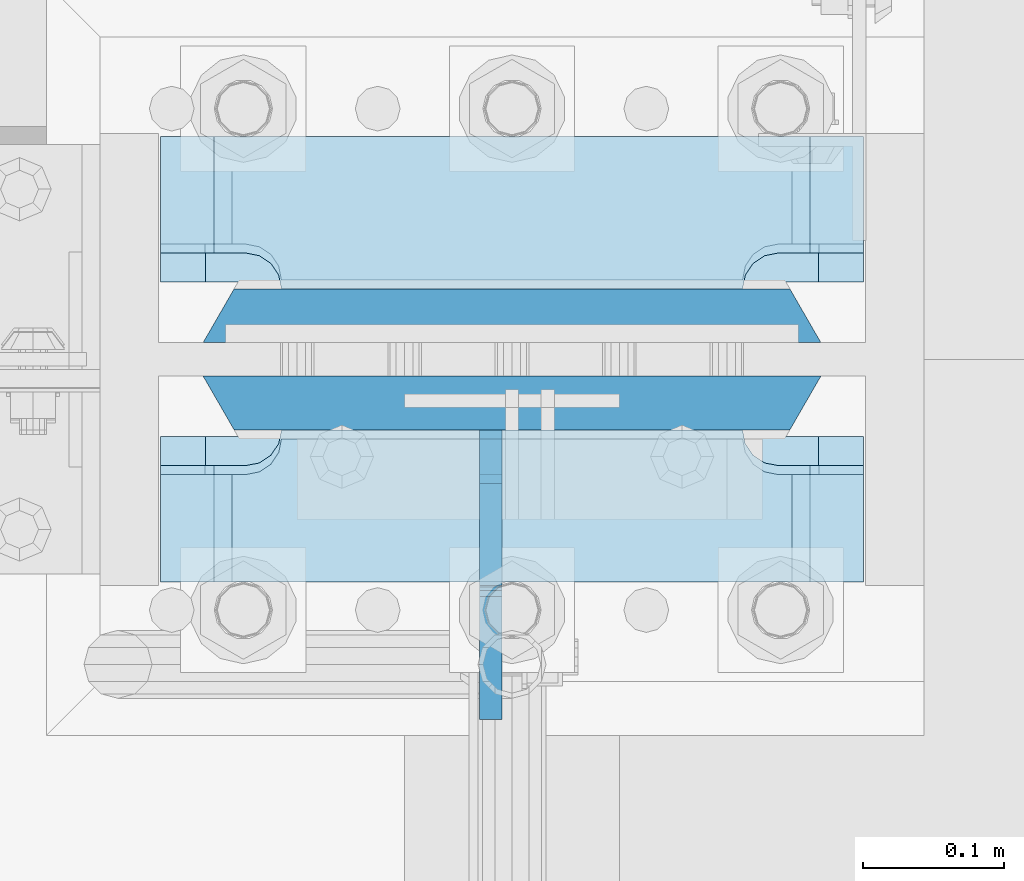
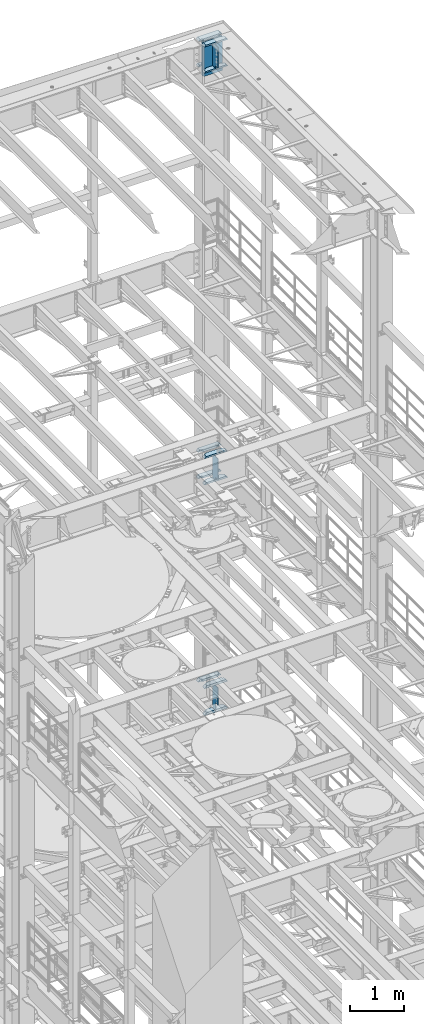
# One storey, part 1829 of 1876: 16 plates, 2 elements without a shape of their own.
"""IFC2X3 building model written with IfcOpenShell, lengths in millimetres."""

from ifc_helpers import new_model, si_unit, frame, origin_with_axes, place, context, subcontext, project, spatial, faceted_brep, material, type_object, element, aggregate, save


model = new_model("IFC2X3")

# Units and contexts
model_context = context("Model", 3, precision=1e-05, world=origin_with_axes())
body_context = subcontext(model_context, "Body", "Model", "MODEL_VIEW")
ifc_project = project(units=[si_unit("LENGTHUNIT", "METRE", prefix="MILLI"), si_unit("AREAUNIT", "SQUARE_METRE"), si_unit("VOLUMEUNIT", "CUBIC_METRE"), si_unit("MASSUNIT", "GRAM", prefix="KILO"), si_unit("TIMEUNIT", "SECOND"), si_unit("PLANEANGLEUNIT", "RADIAN"), si_unit("SOLIDANGLEUNIT", "STERADIAN"), si_unit("THERMODYNAMICTEMPERATUREUNIT", "DEGREE_CELSIUS"), si_unit("LUMINOUSINTENSITYUNIT", "LUMEN")], contexts=[model_context])

# Site, building, storey
site_placement = place(None, origin_with_axes())
site = spatial("IfcSite", under=ifc_project, at=site_placement, CompositionType="ELEMENT")
building_placement = place(site_placement, origin_with_axes())
building = spatial("IfcBuilding", under=site, at=building_placement, Name="Undefined", CompositionType="ELEMENT")
storey_placement = place(building_placement, origin_with_axes())
storey = spatial("IfcBuildingStorey", under=building, at=storey_placement, Name="Undefined", CompositionType="ELEMENT", Elevation=0.0)

# Assembly, plates
assembly_1_placement = place(storey_placement, origin_with_axes())
assembly_1 = element("IfcElementAssembly", 1, at=assembly_1_placement, inside=storey, Name="COLUMN", AssemblyPlace="NOTDEFINED", PredefinedType="RIGID_FRAME")
ifc_material_1 = material(Name="STEEL/A572-GR.50")
plate_type_1 = type_object("IfcPlateType", PredefinedType="NOTDEFINED")
plate_1_placement = place(assembly_1_placement, frame((7839.075, 13685.04375, 22523.45), z_axis=(-1.0, 0.0, 0.0), x_axis=(0.0, 0.0, -1.0)))
plate_1 = element("IfcPlate", 2, at=plate_1_placement, type_object=plate_type_1, material=ifc_material_1, Name="PLATE", context=body_context, shape_type="Brep", body=[
    faceted_brep([(0.0, 19.0500000000002, 416.152954742277), (0.0, -19.0500000000002, 438.149993896484), (742.950012207031, -19.0500000000002, 438.149993896484), (742.950012207031, 19.0500000000002, 416.152954742277), (742.950012207031, 19.0500000000002, 21.9970452577325), (0.0, 19.0500000000002, 21.9970452577367), (0.0, -19.0500000000002, 0.0), (742.950012207031, -19.0500000000002, 0.0)], [[[0, 1, 2, 3]], [[0, 3, 4, 5]], [[1, 0, 5, 6]], [[2, 1, 6, 7]], [[3, 2, 7, 4]], [[6, 5, 4, 7]]]),
])
plate_2_placement = place(assembly_1_placement, frame((7839.075, 13746.95625, 22523.45), z_axis=(-1.0, 0.0, 0.0), x_axis=(0.0, 0.0, -1.0)))
plate_2 = element("IfcPlate", 3, at=plate_2_placement, type_object=plate_type_1, material=ifc_material_1, Name="PLATE", context=body_context, shape_type="Brep", body=[
    faceted_brep([(0.0, -19.0500000000002, 416.152954749452), (742.950012207031, -19.0500000000002, 416.152954749372), (742.950012207031, 19.0500000000002, 438.149993896484), (0.0, 19.0500000000002, 438.149993896484), (742.950012207031, -19.0500000000002, 21.9970452506512), (742.950012207031, 19.0500000000002, 0.0), (-9.09494701772928e-13, 19.05, -1.81898940354586e-12), (0.0, -19.0500000000002, 21.9970452506512)], [[[0, 1, 2, 3]], [[2, 1, 4, 5]], [[3, 2, 5, 6]], [[0, 3, 6, 7]], [[1, 0, 7, 4]], [[6, 5, 4, 7]]]),
])

assembly_2_placement = place(storey_placement, origin_with_axes())
assembly_2 = element("IfcElementAssembly", 4, at=assembly_2_placement, inside=storey, Name="COLUMN", AssemblyPlace="NOTDEFINED", PredefinedType="RIGID_FRAME")
ifc_material_2 = material(Name="STEEL/A572-50")
plate_type_2 = type_object("IfcPlateType", PredefinedType="NOTDEFINED")
plate_3_placement = place(assembly_2_placement, frame((7370.7625, 13558.04375, 7524.75002441406), z_axis=(1.0, 0.0, 0.0), x_axis=(0.0, 1.0, 0.0)))
plate_3 = element("IfcPlate", 5, at=plate_3_placement, type_object=plate_type_2, material=ifc_material_2, Name="PLATE", context=body_context, shape_type="Brep", body=[
    faceted_brep([(76.1999988555908, -25.3999999999996, 498.475006103516), (76.1999988555908, 25.3999999999996, 447.975004579812), (0.0, 25.3999999999996, 447.975004579812), (0.0, -25.3999999999996, 498.475006103516), (76.1999988555908, 25.3999999999996, 50.5000015237032), (76.1999988555908, -25.3999999999996, 0.0), (0.0, -25.3999996185375, 0.0), (0.0, 25.3999999999996, 50.5000015237032), (76.1999988555908, 25.3999999999996, 60.3249988555908), (76.1999988555908, -25.3999999999996, 60.3249988555908), (78.1334587007668, -25.3999999999996, 70.045157891682), (78.1334587007668, 25.3999999999996, 70.045157891682), (83.6394865017228, -25.3999999999996, 78.2855108279893), (83.6394865017228, 25.3999999999996, 78.2855108279893), (91.8798394380301, -25.3999999999996, 83.7915386289454), (91.8798394380301, 25.3999999999996, 83.7915386289454), (101.599998474121, -25.3999999999996, 85.7249984741211), (101.599998474121, 25.3999999999996, 85.7249984741211), (101.599998474121, -25.3999999999996, 412.750007629395), (101.599998474121, 25.3999999999996, 412.750007629395), (91.8798394380301, -25.3999999999996, 414.68346747457), (91.8798394380301, 25.3999999999996, 414.68346747457), (83.6394865017219, -25.3999999999996, 420.189495275526), (83.6394865017219, 25.3999999999996, 420.189495275526), (78.1334587007659, -25.3999999999996, 428.429848211834), (78.1334587007659, 25.3999999999996, 428.429848211834), (76.1999988555908, -25.3999999999996, 438.150007247925), (76.1999988555908, 25.3999999999996, 438.150007247925)], [[[0, 1, 2, 3]], [[4, 5, 6, 7]], [[8, 9, 5, 4]], [[10, 9, 8, 11]], [[12, 10, 11, 13]], [[14, 12, 13, 15]], [[16, 14, 15, 17]], [[18, 16, 17, 19]], [[20, 18, 19, 21]], [[22, 20, 21, 23]], [[24, 22, 23, 25]], [[26, 24, 25, 27]], [[6, 5, 9, 10, 12, 14, 16, 18, 20, 22, 24, 26, 0, 3]], [[7, 6, 3, 2]], [[27, 25, 23, 21, 19, 17, 15, 13, 11, 8, 4, 7, 2, 1]], [[26, 27, 1, 0]]]),
])
plate_4_placement = place(assembly_2_placement, frame((7370.7625, 13772.35625, 8128.0), z_axis=(1.0, 0.0, 0.0), x_axis=(0.0, 1.0, 0.0)))
plate_4 = element("IfcPlate", 6, at=plate_4_placement, type_object=plate_type_2, material=ifc_material_2, Name="PLATE", context=body_context, shape_type="Brep", body=[
    faceted_brep([(101.599998474121, -25.3999999999996, 498.475006103516), (101.599998474121, 25.3999999999996, 447.975004579813), (25.3999996185303, 25.3999999999996, 447.975004579813), (25.3999996185303, -25.3999999999996, 498.475006103516), (23.4665397733534, -25.3999999999996, 428.429848211837), (25.3999996185303, -25.3999999999996, 438.150007247925), (25.3999996185303, 25.3999999999996, 438.150007247925), (23.4665397733534, 25.3999999999996, 428.429848211837), (17.9605119723965, -25.3999999999996, 420.189495275529), (17.9605119723965, 25.3999999999996, 420.189495275529), (9.72015903608917, -25.3999999999996, 414.683467474573), (9.72015903608917, 25.3999999999996, 414.683467474573), (0.0, -25.3999999999996, 412.750007629395), (0.0, 25.3999999999996, 412.750007629395), (0.0, -25.3999999999996, 85.7249984741211), (0.0, 25.3999999999996, 85.7249984741211), (9.72015903609099, -25.3999999999996, 83.7915386289451), (9.72015903609099, 25.3999999999996, 83.7915386289451), (17.9605119723983, -25.3999999999996, 78.2855108279891), (17.9605119723983, 25.3999999999996, 78.2855108279891), (23.4665397733552, -25.3999999999996, 70.0451578916818), (23.4665397733552, 25.3999999999996, 70.0451578916818), (25.3999996185303, -25.3999999999996, 60.3249988555908), (25.3999996185303, 25.3999999999996, 60.3249988555908), (25.3999996185303, 25.3999999999996, 50.5000015237028), (25.3999996185303, -25.3999999999996, 0.0), (101.599998474121, 25.3999999999996, 50.5000015237028), (101.599998474121, -25.3999999999996, 0.0)], [[[0, 1, 2, 3]], [[4, 5, 6, 7]], [[8, 4, 7, 9]], [[10, 8, 9, 11]], [[12, 10, 11, 13]], [[14, 12, 13, 15]], [[16, 14, 15, 17]], [[18, 16, 17, 19]], [[20, 18, 19, 21]], [[22, 20, 21, 23]], [[22, 23, 24, 25]], [[26, 27, 25, 24]], [[5, 4, 8, 10, 12, 14, 16, 18, 20, 22, 25, 27, 0, 3]], [[6, 5, 3, 2]], [[26, 24, 23, 21, 19, 17, 15, 13, 11, 9, 7, 6, 2, 1]], [[27, 26, 1, 0]]]),
])
plate_5_placement = place(assembly_2_placement, frame((7370.7625, 13558.04375, 8128.0), z_axis=(1.0, 0.0, 0.0), x_axis=(0.0, 1.0, 0.0)))
plate_5 = element("IfcPlate", 7, at=plate_5_placement, type_object=plate_type_2, material=ifc_material_2, Name="PLATE", context=body_context, shape_type="Brep", body=[
    faceted_brep([(76.1999988555908, -25.3999999999996, 498.475006103516), (76.1999988555908, 25.3999999999996, 447.975004579812), (0.0, 25.3999999999996, 447.975004579812), (0.0, -25.3999999999996, 498.475006103516), (76.1999988555908, 25.3999999999996, 50.5000015237032), (76.1999988555908, -25.3999999999996, 0.0), (0.0, -25.3999996185375, 0.0), (0.0, 25.3999999999996, 50.5000015237032), (76.1999988555908, 25.3999999999996, 60.3249988555908), (76.1999988555908, -25.3999999999996, 60.3249988555908), (78.1334587007668, -25.3999999999996, 70.045157891682), (78.1334587007668, 25.3999999999996, 70.045157891682), (83.6394865017228, -25.3999999999996, 78.2855108279893), (83.6394865017228, 25.3999999999996, 78.2855108279893), (91.8798394380301, -25.3999999999996, 83.7915386289454), (91.8798394380301, 25.3999999999996, 83.7915386289454), (101.599998474121, -25.3999999999996, 85.7249984741211), (101.599998474121, 25.3999999999996, 85.7249984741211), (101.599998474121, -25.3999999999996, 412.750007629395), (101.599998474121, 25.3999999999996, 412.750007629395), (91.8798394380301, -25.3999999999996, 414.68346747457), (91.8798394380301, 25.3999999999996, 414.68346747457), (83.6394865017219, -25.3999999999996, 420.189495275526), (83.6394865017219, 25.3999999999996, 420.189495275526), (78.1334587007659, -25.3999999999996, 428.429848211834), (78.1334587007659, 25.3999999999996, 428.429848211834), (76.1999988555908, -25.3999999999996, 438.150007247925), (76.1999988555908, 25.3999999999996, 438.150007247925)], [[[0, 1, 2, 3]], [[4, 5, 6, 7]], [[8, 9, 5, 4]], [[10, 9, 8, 11]], [[12, 10, 11, 13]], [[14, 12, 13, 15]], [[16, 14, 15, 17]], [[18, 16, 17, 19]], [[20, 18, 19, 21]], [[22, 20, 21, 23]], [[24, 22, 23, 25]], [[26, 24, 25, 27]], [[6, 5, 9, 10, 12, 14, 16, 18, 20, 22, 24, 26, 0, 3]], [[7, 6, 3, 2]], [[27, 25, 23, 21, 19, 17, 15, 13, 11, 8, 4, 7, 2, 1]], [[26, 27, 1, 0]]]),
])

# Plate
plate_type_3 = type_object("IfcPlateType", PredefinedType="NOTDEFINED")
plate_6_placement = place(assembly_1_placement, frame((7370.7625, 13766.00625, 21948.775012207), z_axis=(1.0, 0.0, 0.0), x_axis=(0.0, 1.0, 0.0)))
plate_6 = element("IfcPlate", 8, at=plate_6_placement, type_object=plate_type_3, material=ifc_material_2, Name="PLATE", context=body_context, shape_type="Brep", body=[
    faceted_brep([(107.949996948242, -15.875, 498.475006103516), (107.949996948242, 15.875, 467.025007631571), (25.3999996185303, 15.875, 467.025007631571), (25.3999996185303, -15.875, 498.475006103516), (23.4665397733534, -15.875, 428.429848211837), (25.3999996185303, -15.875, 438.150007247925), (25.3999996185303, 15.875, 438.150007247925), (23.4665397733534, 15.875, 428.429848211837), (17.9605119723965, -15.875, 420.189495275529), (17.9605119723965, 15.875, 420.189495275529), (9.72015903608917, -15.875, 414.683467474573), (9.72015903608917, 15.875, 414.683467474573), (0.0, -15.875, 412.750007629395), (0.0, 15.875, 412.750007629395), (0.0, -15.875, 85.7249984741211), (0.0, 15.875, 85.7249984741211), (9.72015903609099, -15.875, 83.7915386289454), (9.72015903609099, 15.875, 83.7915386289454), (17.9605119723983, -15.875, 78.2855108279892), (17.9605119723983, 15.875, 78.2855108279892), (23.4665397733552, -15.875, 70.0451578916817), (23.4665397733552, 15.875, 70.0451578916817), (25.3999996185303, -15.875, 60.3249988555908), (25.3999996185303, 15.875, 60.3249988555908), (25.3999996185303, 15.875, 31.449998471945), (25.3999996185303, -15.875, 0.0), (107.949996948242, 15.875, 31.449998471945), (107.949996948242, -15.875, 0.0)], [[[0, 1, 2, 3]], [[4, 5, 6, 7]], [[8, 4, 7, 9]], [[10, 8, 9, 11]], [[12, 10, 11, 13]], [[14, 12, 13, 15]], [[16, 14, 15, 17]], [[18, 16, 17, 19]], [[20, 18, 19, 21]], [[22, 20, 21, 23]], [[22, 23, 24, 25]], [[26, 27, 25, 24]], [[5, 4, 8, 10, 12, 14, 16, 18, 20, 22, 25, 27, 0, 3]], [[6, 5, 3, 2]], [[26, 24, 23, 21, 19, 17, 15, 13, 11, 9, 7, 6, 2, 1]], [[27, 26, 1, 0]]]),
])

plate_7_placement = place(assembly_1_placement, frame((7370.7625, 13558.04375, 21948.775012207), z_axis=(1.0, 0.0, 0.0), x_axis=(0.0, 1.0, 0.0)))
plate_7 = element("IfcPlate", 9, at=plate_7_placement, type_object=plate_type_3, material=ifc_material_2, Name="PLATE", context=body_context, shape_type="Brep", body=[
    faceted_brep([(82.5499973297119, -15.875, 498.475006103516), (82.5499973297119, 15.875, 467.025007631571), (0.0, 15.875, 467.025007631571), (0.0, -15.875, 498.475006103516), (82.5499973297119, 15.875, 31.449998471945), (82.5499973297119, -15.875, 0.0), (0.0, -15.875, 0.0), (0.0, 15.875, 31.449998471945), (82.5499973297119, 15.875, 60.3249988555908), (82.5499973297119, -15.875, 60.3249988555908), (84.4834571748879, -15.875, 70.045157891682), (84.4834571748879, 15.875, 70.045157891682), (89.9894849758439, -15.875, 78.2855108279893), (89.9894849758439, 15.875, 78.2855108279893), (98.2298379121512, -15.875, 83.7915386289454), (98.2298379121512, 15.875, 83.7915386289454), (107.949996948242, -15.875, 85.7249984741211), (107.949996948242, 15.875, 85.7249984741211), (107.949996948242, -15.875, 412.750007629395), (107.949996948242, 15.875, 412.750007629395), (98.2298379121512, -15.875, 414.68346747457), (98.2298379121512, 15.875, 414.68346747457), (89.989484975843, -15.875, 420.189495275526), (89.989484975843, 15.875, 420.189495275526), (84.483457174887, -15.875, 428.429848211834), (84.483457174887, 15.875, 428.429848211834), (82.5499973297119, -15.875, 438.150007247925), (82.5499973297119, 15.875, 438.150007247925)], [[[0, 1, 2, 3]], [[4, 5, 6, 7]], [[8, 9, 5, 4]], [[10, 9, 8, 11]], [[12, 10, 11, 13]], [[14, 12, 13, 15]], [[16, 14, 15, 17]], [[18, 16, 17, 19]], [[20, 18, 19, 21]], [[22, 20, 21, 23]], [[24, 22, 23, 25]], [[26, 24, 25, 27]], [[6, 5, 9, 10, 12, 14, 16, 18, 20, 22, 24, 26, 0, 3]], [[7, 6, 3, 2]], [[27, 25, 23, 21, 19, 17, 15, 13, 11, 8, 4, 7, 2, 1]], [[26, 27, 1, 0]]]),
])

ifc_material_3 = material(Name="STEEL/A36")
plate_type_4 = type_object("IfcPlateType", PredefinedType="NOTDEFINED")
plate_8_placement = place(assembly_1_placement, frame((7604.91875, 13665.99375, 22523.45), z_axis=(0.0, -1.0, 0.0), x_axis=(0.0, 0.0, -1.0)))
plate_8 = element("IfcPlate", 10, at=plate_8_placement, type_object=plate_type_4, material=ifc_material_3, Name="PLATE", context=body_context, shape_type="Brep", body=[
    faceted_brep([(488.949999999997, -7.93749999999998, 205.581253456207), (488.949999999997, -7.93749999999998, 120.649999809266), (488.949999999997, 7.93749999999999, 120.649999809266), (488.949999999997, 7.93749999999999, 205.581253051758), (489.916729922585, -7.93749999999998, 115.78992029122), (489.916729922585, 7.93749999999999, 115.78992029122), (492.669743823062, -7.93749999999998, 111.669743823067), (492.669743823062, 7.93749999999999, 111.669743823067), (496.789920291216, -7.93749999999998, 108.916729922588), (496.789920291216, 7.93749999999999, 108.916729922588), (501.649999809262, -7.93749999999998, 107.950000000001), (501.649999809262, 7.93749999999999, 107.950000000001), (558.799987792969, -7.93749999999998, 107.950000000001), (558.799987792969, 7.93749999999999, 107.950000000001), (31.7499984741225, -7.93749999999998, 205.581256103516), (31.7499984741225, 7.93749999999999, 205.581253051758), (31.7499984741225, 7.93749999999999, 120.649999809266), (31.7499984741225, -7.93749999999998, 120.649999809266), (30.783268551535, 7.93749999999999, 115.78992029122), (30.783268551535, -7.93749999999998, 115.78992029122), (28.0302546510575, 7.93749999999999, 111.669743823067), (28.0302546510575, -7.93749999999998, 111.669743823067), (23.9100781829038, 7.93749999999999, 108.916729922588), (23.9100781829038, -7.93749999999998, 108.916729922588), (19.0499986648574, 7.93749999999999, 107.950000000001), (19.0499986648574, -7.93749999999998, 107.950000000001), (0.0, 7.93749999999999, 107.950000000001), (0.0, -7.93749999999998, 107.950000000001), (0.0, 7.93749999999999, 31.75), (0.0, -7.93749999999998, 31.75), (31.75, -7.93749999999998, 0.0), (31.75, 7.93749999999999, 0.0), (527.049987792969, -7.93749999999998, 0.0), (527.049987792969, 7.93749999999999, 0.0), (558.799987792969, -7.93749999999998, 31.75), (558.799987792969, 7.93749999999999, 31.75)], [[[0, 1, 2, 3]], [[4, 5, 2, 1]], [[6, 7, 5, 4]], [[8, 9, 7, 6]], [[10, 11, 9, 8]], [[12, 13, 11, 10]], [[14, 15, 16, 17]], [[17, 16, 18, 19]], [[19, 18, 20, 21]], [[21, 20, 22, 23]], [[23, 22, 24, 25]], [[25, 24, 26, 27]], [[28, 29, 27, 26]], [[30, 29, 28, 31]], [[32, 30, 31, 33]], [[34, 32, 33, 35]], [[8, 6, 4, 1, 0, 14, 17, 19, 21, 23, 25, 27, 29, 30, 32, 34, 12, 10]], [[15, 14, 0, 3]], [[35, 33, 31, 28, 26, 24, 22, 20, 18, 16, 15, 3, 2, 5, 7, 9, 11, 13]], [[34, 35, 13, 12]]]),
])

plate_9_placement = place(assembly_2_placement, frame((7604.91949987411, 13665.99375, 13271.5), z_axis=(0.0, -1.0, 0.0), x_axis=(0.0, 0.0, -1.0)))
plate_9 = element("IfcPlate", 11, at=plate_9_placement, type_object=plate_type_4, material=ifc_material_3, Name="PLATE", context=body_context, shape_type="Brep", body=[
    faceted_brep([(482.600012207031, -7.9375, 205.581252647308), (482.600012207031, -7.9375, 123.031246757508), (482.600012207031, 7.9375, 123.031246757508), (482.600012207031, 7.9375, 205.581253051758), (483.566742129618, -7.9375, 118.171167239462), (483.566742129618, 7.9375, 118.171167239462), (486.319756030096, -7.9375, 114.050990771309), (486.319756030096, 7.9375, 114.050990771309), (490.43993249825, -7.9375, 111.29797687083), (490.43993249825, 7.9375, 111.29797687083), (495.300012016296, -7.9375, 110.331246948243), (495.300012016296, 7.9375, 110.331246948243), (552.450012207031, -7.9375, 110.331246948243), (552.450012207031, 7.9375, 110.331246948243), (25.3999996185303, -7.9375, 205.581249999999), (25.3999996185303, 7.9375, 205.581253051758), (25.3999996185303, 7.9375, 123.031249809264), (25.3999996185303, -7.9375, 123.031249809264), (24.4332696959427, 7.9375, 118.171170291219), (24.4332696959427, -7.9375, 118.171170291219), (21.6802557954652, 7.9375, 114.050993823065), (21.6802557954652, -7.9375, 114.050993823065), (17.5600793273115, 7.9375, 111.297979922587), (17.5600793273115, -7.9375, 111.297979922587), (12.6999998092651, 7.9375, 110.331249999999), (12.6999998092651, -7.9375, 110.331249999999), (0.0, 7.9375, 110.33125), (0.0, -7.9375, 110.33125), (0.0, 7.93749999999999, 31.75), (0.0, -7.93749999999998, 31.75), (31.75, -7.93749999999998, 0.0), (31.75, 7.93749999999999, 0.0), (520.700012207031, -7.9375, 0.0), (520.700012207031, 7.9375, 0.0), (552.450012207031, -7.9375, 31.75), (552.450012207031, 7.9375, 31.75)], [[[0, 1, 2, 3]], [[4, 5, 2, 1]], [[6, 7, 5, 4]], [[8, 9, 7, 6]], [[10, 11, 9, 8]], [[12, 13, 11, 10]], [[14, 15, 16, 17]], [[17, 16, 18, 19]], [[19, 18, 20, 21]], [[21, 20, 22, 23]], [[23, 22, 24, 25]], [[25, 24, 26, 27]], [[28, 29, 27, 26]], [[30, 29, 28, 31]], [[32, 30, 31, 33]], [[34, 32, 33, 35]], [[8, 6, 4, 1, 0, 14, 17, 19, 21, 23, 25, 27, 29, 30, 32, 34, 12, 10]], [[15, 14, 0, 3]], [[35, 33, 31, 28, 26, 24, 22, 20, 18, 16, 15, 3, 2, 5, 7, 9, 11, 13]], [[34, 35, 13, 12]]]),
])

plate_type_5 = type_object("IfcPlateType", PredefinedType="NOTDEFINED")
plate_10_placement = place(assembly_2_placement, frame((7370.7625, 13766.00625, 12699.999987793), z_axis=(1.0, 0.0, 0.0), x_axis=(0.0, 1.0, 0.0)))
plate_10 = element("IfcPlate", 12, at=plate_10_placement, type_object=plate_type_5, material=ifc_material_2, Name="PLATE", context=body_context, shape_type="Brep", body=[
    faceted_brep([(107.949996948242, -19.0499999999993, 498.475006103516), (107.949996948242, 19.0499999999993, 460.675005342751), (25.3999996185303, 19.0499999999993, 460.675005342751), (25.3999996185303, -19.0499999999993, 498.475006103516), (23.4665397733534, -19.0499999999993, 428.429848211837), (25.3999996185303, -19.0499999999993, 438.150007247925), (25.3999996185303, 19.0499999999993, 438.150007247925), (23.4665397733534, 19.0499999999993, 428.429848211837), (17.9605119723965, -19.0499999999993, 420.189495275529), (17.9605119723965, 19.0499999999993, 420.189495275529), (9.72015903608917, -19.0499999999993, 414.683467474573), (9.72015903608917, 19.0499999999993, 414.683467474573), (0.0, -19.0499999999993, 412.750007629395), (0.0, 19.0499999999993, 412.750007629395), (0.0, -19.0499999999993, 85.7249984741211), (0.0, 19.0499999999993, 85.7249984741211), (9.72015903609099, -19.0499999999993, 83.7915386289451), (9.72015903609099, 19.0499999999993, 83.7915386289451), (17.9605119723983, -19.0499999999993, 78.2855108279891), (17.9605119723983, 19.0499999999993, 78.2855108279891), (23.4665397733552, -19.0499999999993, 70.0451578916818), (23.4665397733552, 19.0499999999993, 70.0451578916818), (25.3999996185303, -19.0499999999993, 60.3249988555908), (25.3999996185303, 19.0499999999993, 60.3249988555908), (25.3999996185303, 19.0499999999993, 37.8000007607643), (25.3999996185303, -19.0499999999993, 0.0), (107.949996948242, 19.0499999999993, 37.8000007607643), (107.949996948242, -19.0499999999993, 0.0)], [[[0, 1, 2, 3]], [[4, 5, 6, 7]], [[8, 4, 7, 9]], [[10, 8, 9, 11]], [[12, 10, 11, 13]], [[14, 12, 13, 15]], [[16, 14, 15, 17]], [[18, 16, 17, 19]], [[20, 18, 19, 21]], [[22, 20, 21, 23]], [[22, 23, 24, 25]], [[26, 27, 25, 24]], [[5, 4, 8, 10, 12, 14, 16, 18, 20, 22, 25, 27, 0, 3]], [[6, 5, 3, 2]], [[26, 24, 23, 21, 19, 17, 15, 13, 11, 9, 7, 6, 2, 1]], [[27, 26, 1, 0]]]),
])

plate_11_placement = place(assembly_2_placement, frame((7370.7625, 13766.00625, 13290.55), z_axis=(1.0, 0.0, 0.0), x_axis=(0.0, 1.0, 0.0)))
plate_11 = element("IfcPlate", 13, at=plate_11_placement, type_object=plate_type_5, material=ifc_material_2, Name="PLATE", context=body_context, shape_type="Brep", body=[
    faceted_brep([(107.949996948242, -19.0499999999993, 498.475006103516), (107.949996948242, 19.0499999999993, 460.675005342751), (25.3999996185303, 19.0499999999993, 460.675005342751), (25.3999996185303, -19.0499999999993, 498.475006103516), (23.4665397733534, -19.0499999999993, 428.429848211837), (25.3999996185303, -19.0499999999993, 438.150007247925), (25.3999996185303, 19.0499999999993, 438.150007247925), (23.4665397733534, 19.0499999999993, 428.429848211837), (17.9605119723965, -19.0499999999993, 420.189495275529), (17.9605119723965, 19.0499999999993, 420.189495275529), (9.72015903608917, -19.0499999999993, 414.683467474573), (9.72015903608917, 19.0499999999993, 414.683467474573), (0.0, -19.0499999999993, 412.750007629395), (0.0, 19.0499999999993, 412.750007629395), (0.0, -19.0499999999993, 85.7249984741211), (0.0, 19.0499999999993, 85.7249984741211), (9.72015903609099, -19.0499999999993, 83.7915386289451), (9.72015903609099, 19.0499999999993, 83.7915386289451), (17.9605119723983, -19.0499999999993, 78.2855108279891), (17.9605119723983, 19.0499999999993, 78.2855108279891), (23.4665397733552, -19.0499999999993, 70.0451578916818), (23.4665397733552, 19.0499999999993, 70.0451578916818), (25.3999996185303, -19.0499999999993, 60.3249988555908), (25.3999996185303, 19.0499999999993, 60.3249988555908), (25.3999996185303, 19.0499999999993, 37.8000007607643), (25.3999996185303, -19.0499999999993, 0.0), (107.949996948242, 19.0499999999993, 37.8000007607643), (107.949996948242, -19.0499999999993, 0.0)], [[[0, 1, 2, 3]], [[4, 5, 6, 7]], [[8, 4, 7, 9]], [[10, 8, 9, 11]], [[12, 10, 11, 13]], [[14, 12, 13, 15]], [[16, 14, 15, 17]], [[18, 16, 17, 19]], [[20, 18, 19, 21]], [[22, 20, 21, 23]], [[22, 23, 24, 25]], [[26, 27, 25, 24]], [[5, 4, 8, 10, 12, 14, 16, 18, 20, 22, 25, 27, 0, 3]], [[6, 5, 3, 2]], [[26, 24, 23, 21, 19, 17, 15, 13, 11, 9, 7, 6, 2, 1]], [[27, 26, 1, 0]]]),
])

plate_12_placement = place(assembly_2_placement, frame((7370.7625, 13558.04375, 12699.999987793), z_axis=(1.0, 0.0, 0.0), x_axis=(0.0, 1.0, 0.0)))
plate_12 = element("IfcPlate", 14, at=plate_12_placement, type_object=plate_type_5, material=ifc_material_2, Name="PLATE", context=body_context, shape_type="Brep", body=[
    faceted_brep([(82.5499973297119, -19.0499999999993, 498.475006103516), (82.5499973297119, 19.0499999999993, 460.675005342751), (0.0, 19.0499999999993, 460.675005342751), (0.0, -19.0499999999993, 498.475006103516), (82.5499973297119, 19.0499999999993, 37.8000007607643), (82.5499973297119, -19.0499999999993, 0.0), (0.0, -19.0500000000002, 0.0), (0.0, 19.0499999999993, 37.8000007607643), (82.5499973297119, 19.0499999999993, 60.3249988555908), (82.5499973297119, -19.0499999999993, 60.3249988555908), (84.4834571748879, -19.0499999999993, 70.0451578916818), (84.4834571748879, 19.0499999999993, 70.0451578916818), (89.9894849758439, -19.0499999999993, 78.2855108279891), (89.9894849758439, 19.0499999999993, 78.2855108279891), (98.2298379121512, -19.0499999999993, 83.7915386289451), (98.2298379121512, 19.0499999999993, 83.7915386289451), (107.949996948242, -19.0499999999993, 85.7249984741211), (107.949996948242, 19.0499999999993, 85.7249984741211), (107.949996948242, -19.0499999999993, 412.750007629395), (107.949996948242, 19.0499999999993, 412.750007629395), (98.2298379121512, -19.0499999999993, 414.683467474571), (98.2298379121512, 19.0499999999993, 414.683467474571), (89.989484975843, -19.0499999999993, 420.189495275526), (89.989484975843, 19.0499999999993, 420.189495275526), (84.483457174887, -19.0499999999993, 428.429848211834), (84.483457174887, 19.0499999999993, 428.429848211834), (82.5499973297119, -19.0499999999993, 438.150007247925), (82.5499973297119, 19.0499999999993, 438.150007247925)], [[[0, 1, 2, 3]], [[4, 5, 6, 7]], [[8, 9, 5, 4]], [[10, 9, 8, 11]], [[12, 10, 11, 13]], [[14, 12, 13, 15]], [[16, 14, 15, 17]], [[18, 16, 17, 19]], [[20, 18, 19, 21]], [[22, 20, 21, 23]], [[24, 22, 23, 25]], [[26, 24, 25, 27]], [[6, 5, 9, 10, 12, 14, 16, 18, 20, 22, 24, 26, 0, 3]], [[7, 6, 3, 2]], [[27, 25, 23, 21, 19, 17, 15, 13, 11, 8, 4, 7, 2, 1]], [[26, 27, 1, 0]]]),
])

plate_13_placement = place(assembly_2_placement, frame((7370.7625, 13558.04375, 13290.55), z_axis=(1.0, 0.0, 0.0), x_axis=(0.0, 1.0, 0.0)))
plate_13 = element("IfcPlate", 15, at=plate_13_placement, type_object=plate_type_5, material=ifc_material_2, Name="PLATE", context=body_context, shape_type="Brep", body=[
    faceted_brep([(82.5499973297119, -19.0499999999993, 498.475006103516), (82.5499973297119, 19.0499999999993, 460.675005342751), (0.0, 19.0499999999993, 460.675005342751), (0.0, -19.0499999999993, 498.475006103516), (82.5499973297119, 19.0499999999993, 37.8000007607643), (82.5499973297119, -19.0499999999993, 0.0), (0.0, -19.0500000000002, 0.0), (0.0, 19.0499999999993, 37.8000007607643), (82.5499973297119, 19.0499999999993, 60.3249988555908), (82.5499973297119, -19.0499999999993, 60.3249988555908), (84.4834571748879, -19.0499999999993, 70.0451578916818), (84.4834571748879, 19.0499999999993, 70.0451578916818), (89.9894849758439, -19.0499999999993, 78.2855108279891), (89.9894849758439, 19.0499999999993, 78.2855108279891), (98.2298379121512, -19.0499999999993, 83.7915386289451), (98.2298379121512, 19.0499999999993, 83.7915386289451), (107.949996948242, -19.0499999999993, 85.7249984741211), (107.949996948242, 19.0499999999993, 85.7249984741211), (107.949996948242, -19.0499999999993, 412.750007629395), (107.949996948242, 19.0499999999993, 412.750007629395), (98.2298379121512, -19.0499999999993, 414.683467474571), (98.2298379121512, 19.0499999999993, 414.683467474571), (89.989484975843, -19.0499999999993, 420.189495275526), (89.989484975843, 19.0499999999993, 420.189495275526), (84.483457174887, -19.0499999999993, 428.429848211834), (84.483457174887, 19.0499999999993, 428.429848211834), (82.5499973297119, -19.0499999999993, 438.150007247925), (82.5499973297119, 19.0499999999993, 438.150007247925)], [[[0, 1, 2, 3]], [[4, 5, 6, 7]], [[8, 9, 5, 4]], [[10, 9, 8, 11]], [[12, 10, 11, 13]], [[14, 12, 13, 15]], [[16, 14, 15, 17]], [[18, 16, 17, 19]], [[20, 18, 19, 21]], [[22, 20, 21, 23]], [[24, 22, 23, 25]], [[26, 24, 25, 27]], [[6, 5, 9, 10, 12, 14, 16, 18, 20, 22, 24, 26, 0, 3]], [[7, 6, 3, 2]], [[27, 25, 23, 21, 19, 17, 15, 13, 11, 8, 4, 7, 2, 1]], [[26, 27, 1, 0]]]),
])

plate_type_6 = type_object("IfcPlateType", PredefinedType="NOTDEFINED")
plate_14_placement = place(assembly_1_placement, frame((7370.7625, 13727.90625, 22539.325), z_axis=(1.0, 0.0, 0.0), x_axis=(0.0, 1.0, 0.0)))
plate_14 = element("IfcPlate", 16, at=plate_14_placement, type_object=plate_type_6, material=ifc_material_2, Name="PLATE", context=body_context, shape_type="Brep", body=[
    faceted_brep([(35.0225766570229, -15.875, 84.7582685515335), (35.0225766570229, 15.875, 84.7582685515335), (39.1427531251766, 15.875, 82.0052546510551), (39.1427531251766, -15.875, 82.0052546510551), (41.895767025655, 15.875, 77.8850781829015), (41.895767025655, -15.875, 77.8850781829015), (42.8624969482426, 15.875, 73.024998664856), (42.8624969482426, -15.875, 73.024998664856), (42.8624969482426, 15.875, 31.7500061035162), (42.8624969482426, -15.875, 0.0), (146.050003051758, 15.875, 31.7500061035162), (146.049995422363, -15.875, 0.0), (146.050003051758, 15.875, 466.725012207031), (146.050003051758, -15.875, 498.475012207031), (42.8624969482426, 15.875, 466.725012207031), (42.8624969482426, -15.875, 498.475), (42.8624969482426, 15.875, 425.450001335144), (42.8624969482426, -15.875, 425.450001335144), (41.895767025655, 15.875, 420.589921817099), (41.895767025655, -15.875, 420.589921817099), (39.1427531251766, 15.875, 416.469745348945), (39.1427531251766, -15.875, 416.469745348945), (35.0225766570229, 15.875, 413.716731448467), (35.0225766570229, -15.875, 413.716731448467), (30.1624971389774, -15.875, 412.750001525879), (31.7500000000036, 15.875, 413.065775478188), (30.1624971389774, 14.2874971389756, 412.750001525879), (0.0, -15.875, 412.750007629395), (30.1624971389774, -15.875, 85.7249984741211), (0.0, -15.875, 85.7249984741211), (30.1624971389774, 14.2874971389756, 85.7249984741211), (31.7500000000036, 15.875, 85.4092245218126)], [[[0, 1, 2, 3]], [[3, 2, 4, 5]], [[5, 4, 6, 7]], [[7, 6, 8, 9]], [[10, 11, 9, 8]], [[11, 10, 12, 13]], [[13, 12, 14, 15]], [[16, 17, 15, 14]], [[17, 16, 18, 19]], [[19, 18, 20, 21]], [[21, 20, 22, 23]], [[24, 23, 22, 25, 26]], [[24, 26, 27]], [[28, 0, 3, 5, 7, 9, 11, 13, 15, 17, 19, 21, 23, 24, 27, 29]], [[28, 29, 30]], [[1, 0, 28, 30, 31]], [[22, 20, 18, 16, 14, 12, 10, 8, 6, 4, 2, 1, 31, 25]], [[30, 29, 27, 26, 25, 31]]]),
])

plate_15_placement = place(assembly_1_placement, frame((7370.76249389648, 13558.04375, 22539.325), z_axis=(1.0, 0.0, 0.0), x_axis=(0.0, 1.0, 0.0)))
plate_15 = element("IfcPlate", 17, at=plate_15_placement, type_object=plate_type_6, material=ifc_material_2, Name="PLATE", context=body_context, shape_type="Brep", body=[
    faceted_brep([(106.907246874825, -15.875, 82.0052546510551), (106.907246874825, 15.875, 82.0052546510551), (111.027423342978, 15.875, 84.7582685515335), (111.027423342978, -15.875, 84.7582685515335), (104.154232974346, -15.875, 77.8850781829015), (104.154232974346, 15.875, 77.8850781829015), (103.187503051759, -15.875, 73.024998664856), (103.187503051759, 15.875, 73.024998664856), (103.187503051759, -15.875, 0.0), (103.187503051759, 15.875, 31.7500061035153), (0.0, -15.875, 0.0), (0.0, 15.875, 31.75), (0.0, -15.875, 498.475006103516), (0.0, 15.875, 466.725006103516), (103.187503051759, -15.875, 498.475012207031), (103.187503051759, 15.875, 466.725012207031), (103.187503051759, -15.875, 425.450001335144), (103.187503051759, 15.875, 425.450001335144), (104.154232974346, -15.875, 420.589921817099), (104.154232974346, 15.875, 420.589921817099), (106.907246874825, -15.875, 416.469745348945), (106.907246874825, 15.875, 416.469745348945), (111.027423342978, -15.875, 413.716731448467), (111.027423342978, 15.875, 413.716731448467), (115.887502861024, -15.875, 412.750001525879), (146.050002288819, -15.875, 412.750001525879), (115.887502861024, 14.2875000396052, 412.750001525879), (114.300003053293, 15.875, 413.06577487085), (114.300003053293, 15.875, 85.4092251291504), (115.887502861024, -15.875, 85.7249984741211), (115.887502861024, 14.2875000396052, 85.7249984741211), (146.050002288819, -15.875, 85.7249984741211)], [[[0, 1, 2, 3]], [[4, 5, 1, 0]], [[6, 7, 5, 4]], [[7, 6, 8, 9]], [[9, 8, 10, 11]], [[11, 10, 12, 13]], [[14, 15, 13, 12]], [[16, 17, 15, 14]], [[18, 19, 17, 16]], [[20, 21, 19, 18]], [[22, 23, 21, 20]], [[24, 25, 26]], [[23, 22, 24, 26, 27]], [[2, 1, 5, 7, 9, 11, 13, 15, 17, 19, 21, 23, 27, 28]], [[29, 3, 2, 28, 30]], [[29, 30, 31]], [[24, 22, 20, 18, 16, 14, 12, 10, 8, 6, 4, 0, 3, 29, 31, 25]], [[30, 28, 27, 26, 25, 31]]]),
])

aggregate(assembly_1, [plate_6, plate_7, plate_8, plate_1, plate_2, plate_14, plate_15])

plate_type_7 = type_object("IfcPlateType", PredefinedType="NOTDEFINED")
plate_16_placement = place(assembly_2_placement, frame((7604.91875, 13659.64375, 8102.6), z_axis=(0.0, -1.0, 0.0), x_axis=(0.0, 0.0, -1.0)))
plate_16 = element("IfcPlate", 18, at=plate_16_placement, type_object=plate_type_7, material=ifc_material_3, Name="PLATE", context=body_context, shape_type="Brep", body=[
    faceted_brep([(380.999987792969, -7.9375, 199.231246948242), (380.999987792969, -7.9375, 116.681246757507), (380.999987792969, 7.9375, 116.681246757507), (380.999987792969, 7.9375, 199.231246948242), (381.966717715557, -7.9375, 111.821167239461), (381.966717715557, 7.9375, 111.821167239461), (384.719731616035, -7.9375, 107.700990771307), (384.719731616035, 7.9375, 107.700990771307), (388.839908084189, -7.9375, 104.94797687083), (388.839908084189, 7.9375, 104.94797687083), (393.699987602235, -7.9375, 103.981246948242), (393.699987602235, 7.9375, 103.981246948242), (552.450012207031, -7.9375, 103.981246948242), (552.450012207031, 7.9375, 103.981246948242), (0.0, -7.93749999999998, 31.75), (0.0, -7.9375, 199.231246948242), (0.0, 7.9375, 199.231246948242), (0.0, 7.93749999999999, 31.75), (31.75, -7.93749999999998, 0.0), (31.75, 7.93749999999999, 0.0), (520.700012207031, -7.9375, 0.0), (520.700012207031, 7.9375, 0.0), (552.450012207031, -7.9375, 31.75), (552.450012207031, 7.9375, 31.75)], [[[0, 1, 2, 3]], [[4, 5, 2, 1]], [[6, 7, 5, 4]], [[8, 9, 7, 6]], [[10, 11, 9, 8]], [[12, 13, 11, 10]], [[14, 15, 16, 17]], [[18, 14, 17, 19]], [[20, 18, 19, 21]], [[22, 20, 21, 23]], [[8, 6, 4, 1, 0, 15, 14, 18, 20, 22, 12, 10]], [[16, 15, 0, 3]], [[23, 21, 19, 17, 16, 3, 2, 5, 7, 9, 11, 13]], [[22, 23, 13, 12]]]),
])

aggregate(assembly_2, [plate_10, plate_11, plate_12, plate_13, plate_9, plate_3, plate_4, plate_5, plate_16])

save(model, "model.ifc")
